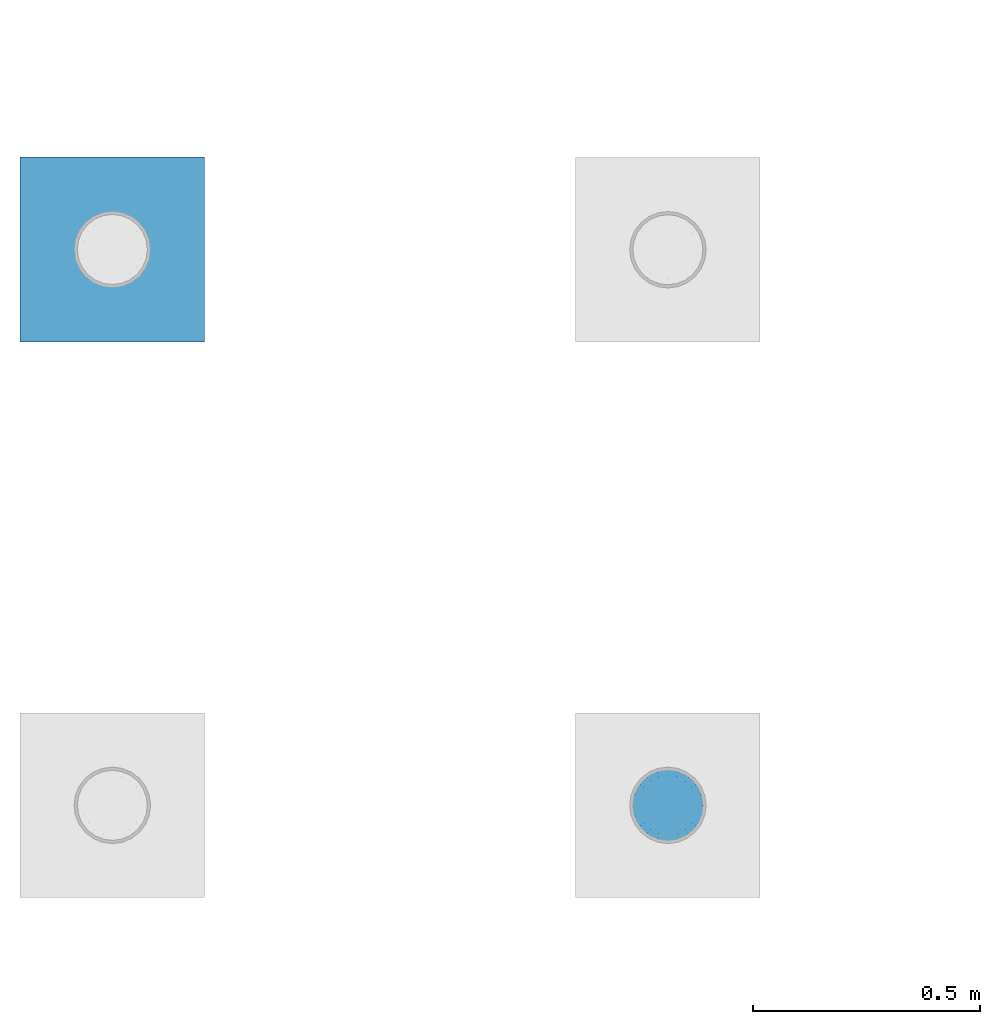
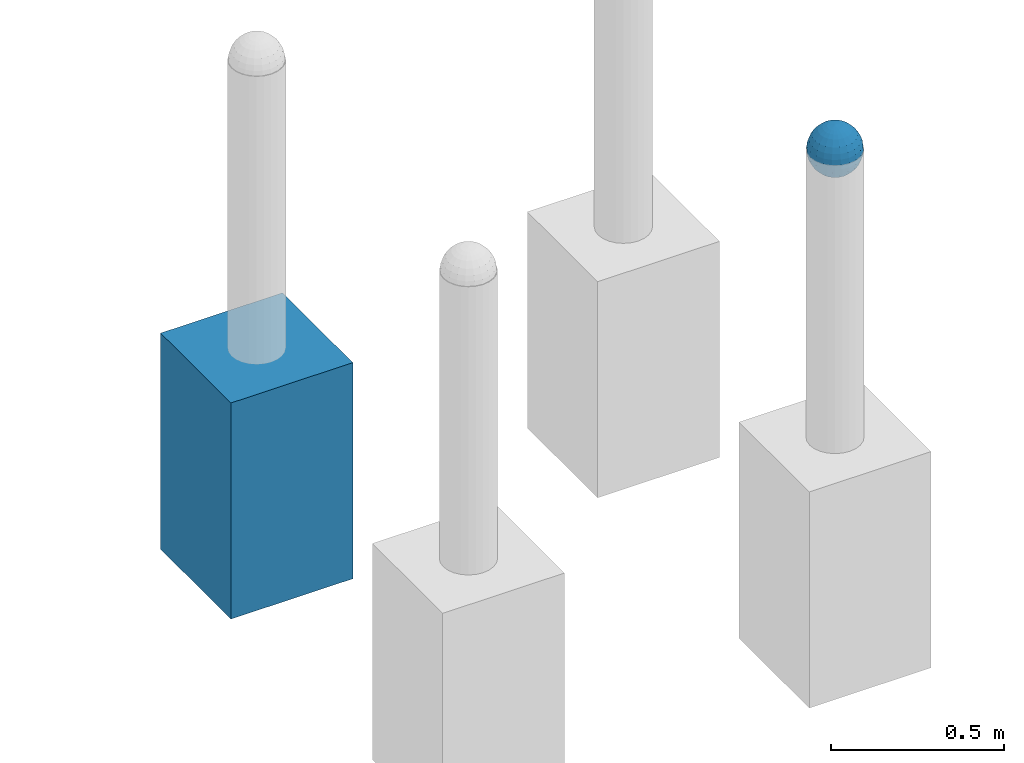
# One storey, part 1433 of 3843: 2 columns, 2 elements without a shape of their own.
"""IFC2X3 building model written with IfcOpenShell, lengths in millimetres."""

from ifc_helpers import new_model, si_unit, frame, origin_with_axes, place, context, subcontext, project, spatial, faceted_brep, material, type_object, element, aggregate, save


model = new_model("IFC2X3")

# Units and contexts
model_context = context("Model", 3, precision=1e-05, world=origin_with_axes())
body_context = subcontext(model_context, "Body", "Model", "MODEL_VIEW")
ifc_project = project(units=[si_unit("LENGTHUNIT", "METRE", prefix="MILLI"), si_unit("AREAUNIT", "SQUARE_METRE"), si_unit("VOLUMEUNIT", "CUBIC_METRE"), si_unit("MASSUNIT", "GRAM", prefix="KILO"), si_unit("TIMEUNIT", "SECOND"), si_unit("PLANEANGLEUNIT", "RADIAN"), si_unit("SOLIDANGLEUNIT", "STERADIAN"), si_unit("THERMODYNAMICTEMPERATUREUNIT", "DEGREE_CELSIUS"), si_unit("LUMINOUSINTENSITYUNIT", "LUMEN")], contexts=[model_context])

# Site, building, storey
site_placement = place(None, origin_with_axes())
site = spatial("IfcSite", under=ifc_project, at=site_placement, CompositionType="ELEMENT")
building_placement = place(site_placement, origin_with_axes())
building = spatial("IfcBuilding", under=site, at=building_placement, Name="Undefined", CompositionType="ELEMENT")
storey_placement = place(building_placement, origin_with_axes())
storey = spatial("IfcBuildingStorey", under=building, at=storey_placement, Name="Undefined", CompositionType="ELEMENT", Elevation=0.0)

# Assembly, column
assembly_1_placement = place(storey_placement, origin_with_axes())
assembly_1 = element("IfcElementAssembly", 1, at=assembly_1_placement, inside=storey, Name="CONC_COL.", AssemblyPlace="NOTDEFINED", PredefinedType="REINFORCEMENT_UNIT")
ifc_material_1 = material(Name="CONCRETE/3000")
column_type_1 = type_object("IfcColumnType", PredefinedType="NOTDEFINED")
column_1_placement = place(assembly_1_placement, frame((-50545.9919130504, 17455.9024050236, 29718.0), z_axis=(-1.0, 0.0, 0.0), x_axis=(0.0, 0.0, 1.0)))
column_1 = element("IfcColumn", 2, at=column_1_placement, type_object=column_type_1, material=ifc_material_1, Name="CONC_COL.", context=body_context, shape_type="Brep", body=[
    faceted_brep([(0.0, 203.199999999997, -203.200000000001), (0.0, 203.199999999997, 203.200000000001), (762.0, 203.199999999997, 203.200000000001), (762.0, 203.199999999997, -203.200000000001), (0.0, -203.199999999997, 203.200000000001), (762.0, -203.199999999997, 203.200000000001), (0.0, -203.199999999997, -203.200000000001), (762.0, -203.199999999997, -203.200000000001)], [[[0, 1, 2, 3]], [[1, 4, 5, 2]], [[4, 6, 7, 5]], [[6, 0, 3, 7]], [[5, 7, 3, 2]], [[6, 4, 1, 0]]]),
])
aggregate(assembly_1, [column_1])

assembly_2_placement = place(storey_placement, origin_with_axes())
assembly_2 = element("IfcElementAssembly", 3, at=assembly_2_placement, inside=storey, Name="CONC. FILL", AssemblyPlace="NOTDEFINED", PredefinedType="REINFORCEMENT_UNIT")
ifc_material_2 = material(Name="CONCRETE/1500")
column_type_2 = type_object("IfcColumnType", PredefinedType="NOTDEFINED")
column_2_placement = place(assembly_2_placement, frame((-49323.3890688121, 16232.6472475529, 31411.8625), z_axis=(-1.0, 0.0, 0.0), x_axis=(0.0, 0.0, 1.0)))
column_2 = element("IfcColumn", 4, at=column_2_placement, type_object=column_type_2, material=ifc_material_2, Name="CONC. FILL", context=body_context, shape_type="Brep", body=[
    faceted_brep([(0.0, 0.0, 2.0), (0.0, -0.619999999995343, 1.89999999999964), (3.36549999999988, -7.1422259999963, 21.9814139999999), (3.36549999999988, 0.0, 23.1139999999996), (0.0, -1.17999999999302, 1.6200000000008), (3.36549999999988, -13.5910319999966, 18.6992260000006), (0.0, -1.61999999999534, 1.18000000000029), (3.36549999999988, -18.699225999997, 13.5910320000003), (0.0, -1.89999999999418, 0.6200000000008), (3.36549999999988, -21.9814139999944, 7.14222599999994), (0.0, -2.0, 0.0), (3.36549999999988, -23.1140000000014, 0.0), (0.0, -1.89999999999418, -0.6200000000008), (3.36549999999988, -21.9814139999944, -7.14222599999994), (0.0, -1.61999999999534, -1.18000000000029), (3.36549999999988, -18.699225999997, -13.5910320000003), (0.0, -1.17999999999302, -1.6200000000008), (3.36549999999988, -13.5910319999966, -18.6992260000006), (0.0, -0.619999999995343, -1.89999999999964), (3.36549999999988, -7.1422259999963, -21.9814139999999), (0.0, 0.0, -2.0), (3.36549999999988, 0.0, -23.1139999999996), (0.0, 0.619999999995343, -1.89999999999964), (3.36549999999988, 7.1422259999963, -21.9814139999999), (0.0, 1.17999999999302, -1.6200000000008), (3.36549999999988, 13.5910319999966, -18.6992260000006), (0.0, 1.61999999999534, -1.18000000000029), (3.36549999999988, 18.699225999997, -13.5910320000003), (0.0, 1.89999999999418, -0.6200000000008), (3.36549999999988, 21.9814139999944, -7.14222599999994), (0.0, 2.0, 0.0), (3.36549999999988, 23.1140000000014, 0.0), (0.0, 1.89999999999418, 0.6200000000008), (3.36549999999988, 21.9814139999944, 7.14222599999994), (0.0, 1.61999999999534, 1.18000000000029), (3.36549999999988, 18.699225999997, 13.5910320000003), (0.0, 1.17999999999302, 1.6200000000008), (3.36549999999988, 13.5910319999966, 18.6992260000006), (0.0, 0.619999999995343, 1.89999999999964), (3.36549999999988, 7.1422259999963, 21.9814139999999), (8.41374999999971, -11.1214661999984, 34.2282018000005), (8.41374999999971, 0.0, 35.9917999999998), (8.41374999999971, -21.1631784000056, 29.1173662000001), (8.41374999999971, -29.1173661999928, 21.1631784000001), (8.41374999999971, -34.2282017999969, 11.1214662000002), (8.41374999999971, -35.9918000000034, 0.0), (8.41374999999971, -34.2282017999969, -11.1214662000002), (8.41374999999971, -29.1173661999928, -21.1631784000001), (8.41374999999971, -21.1631784000056, -29.1173662000001), (8.41374999999971, -11.1214661999984, -34.2282018000005), (8.41374999999971, 0.0, -35.9917999999998), (8.41374999999971, 11.1214661999984, -34.2282018000005), (8.41374999999971, 21.1631784000056, -29.1173662000001), (8.41374999999971, 29.1173661999928, -21.1631784000001), (8.41374999999971, 34.2282017999969, -11.1214662000002), (8.41374999999971, 35.9918000000034, 0.0), (8.41374999999971, 34.2282017999969, 11.1214662000002), (8.41374999999971, 29.1173661999928, 21.1631784000001), (8.41374999999971, 21.1631784000056, 29.1173662000001), (8.41374999999971, 11.1214661999984, 34.2282018000005), (16.8274999999994, -15.3047700000025, 47.1030300000002), (16.8274999999994, 0.0, 49.5300000000007), (16.8274999999994, -29.1236400000053, 40.0697700000001), (16.8274999999994, -40.0697700000019, 29.1236399999998), (16.8274999999994, -47.1030299999984, 15.3047700000006), (16.8274999999994, -49.5299999999988, 0.0), (16.8274999999994, -47.1030299999984, -15.3047700000006), (16.8274999999994, -40.0697700000019, -29.1236399999998), (16.8274999999994, -29.1236400000053, -40.0697700000001), (16.8274999999994, -15.3047700000025, -47.1030300000002), (16.8274999999994, 0.0, -49.5300000000007), (16.8274999999994, 15.3047700000025, -47.1030300000002), (16.8274999999994, 29.1236400000053, -40.0697700000001), (16.8274999999994, 40.0697700000019, -29.1236399999998), (16.8274999999994, 47.1030299999984, -15.3047700000006), (16.8274999999994, 49.5299999999988, 0.0), (16.8274999999994, 47.1030299999984, 15.3047700000006), (16.8274999999994, 40.0697700000019, 29.1236399999998), (16.8274999999994, 29.1236400000053, 40.0697700000001), (16.8274999999994, 15.3047700000025, 47.1030300000002), (33.6549999999988, -20.4063599999936, 62.8040400000009), (33.6549999999988, 0.0, 66.0400000000009), (33.6549999999988, -38.831520000007, 53.4263599999995), (33.6549999999988, -53.4263599999977, 38.8315199999997), (33.6549999999988, -62.8040400000027, 20.4063600000009), (33.6549999999988, -66.0399999999936, 0.0), (33.6549999999988, -62.8040400000027, -20.4063600000009), (33.6549999999988, -53.4263599999977, -38.8315199999997), (33.6549999999988, -38.831520000007, -53.4263599999995), (33.6549999999988, -20.4063599999936, -62.8040400000009), (33.6549999999988, 0.0, -66.0400000000009), (33.6549999999988, 20.4063599999936, -62.8040400000009), (33.6549999999988, 38.831520000007, -53.4263599999995), (33.6549999999988, 53.4263599999977, -38.8315199999997), (33.6549999999988, 62.8040400000027, -20.4063600000009), (33.6549999999988, 66.0399999999936, 0.0), (33.6549999999988, 62.8040400000027, 20.4063600000009), (33.6549999999988, 53.4263599999977, 38.8315199999997), (33.6549999999988, 38.831520000007, 53.4263599999995), (33.6549999999988, 20.4063599999936, 62.8040400000009), (50.4824999999983, -23.3907901500061, 71.9891308499991), (50.4824999999983, 0.0, 75.6983500000006), (50.4824999999983, -44.5106298000028, 61.23996515), (50.4824999999983, -61.2399651500018, 44.5106297999992), (50.4824999999983, -71.9891308499937, 23.3907901500006), (50.4824999999983, -75.698350000006, 0.0), (50.4824999999983, -71.9891308499937, -23.3907901500006), (50.4824999999983, -61.2399651500018, -44.5106297999992), (50.4824999999983, -44.5106298000028, -61.23996515), (50.4824999999983, -23.3907901500061, -71.9891308499991), (50.4824999999983, 0.0, -75.6983500000006), (50.4824999999983, 23.3907901500061, -71.9891308499991), (50.4824999999983, 44.5106298000028, -61.23996515), (50.4824999999983, 61.2399651500018, -44.5106297999992), (50.4824999999983, 71.9891308499937, -23.3907901500006), (50.4824999999983, 75.698350000006, 0.0), (50.4824999999983, 71.9891308499937, 23.3907901500006), (50.4824999999983, 61.2399651500018, 44.5106297999992), (50.4824999999983, 44.5106298000028, 61.23996515), (50.4824999999983, 23.3907901500061, 71.9891308499991), (67.3099999999977, -24.9977910000016, 76.9349490000004), (67.3099999999977, 0.0, 80.8989999999994), (67.3099999999977, -47.5686120000028, 65.4472910000004), (67.3099999999977, -65.447291000004, 47.5686119999991), (67.3099999999977, -76.9349490000022, 24.9977909999998), (67.3099999999977, -80.8990000000049, 0.0), (67.3099999999977, -76.9349490000022, -24.9977909999998), (67.3099999999977, -65.447291000004, -47.5686119999991), (67.3099999999977, -47.5686120000028, -65.4472910000004), (67.3099999999977, -24.9977910000016, -76.9349490000004), (67.3099999999977, 0.0, -80.8989999999994), (67.3099999999977, 24.9977910000016, -76.9349490000004), (67.3099999999977, 47.5686120000028, -65.4472910000004), (67.3099999999977, 65.447291000004, -47.5686119999991), (67.3099999999977, 76.9349490000022, -24.9977909999998), (67.3099999999977, 80.8990000000049, 0.0), (67.3099999999977, 76.9349490000022, 24.9977909999998), (67.3099999999977, 65.447291000004, 47.5686119999991), (67.3099999999977, 47.5686120000028, 65.4472910000004), (67.3099999999977, 24.9977910000016, 76.9349490000004), (84.1374999999935, -25.5079499999993, 78.5050499999998), (84.1374999999935, 0.0, 82.5499999999993), (84.1374999999935, -48.5393999999942, 66.7829500000007), (84.1374999999935, -66.7829499999934, 48.5393999999997), (84.1374999999935, -78.505050000007, 25.5079499999993), (84.1374999999935, -82.5500000000029, 0.0), (84.1374999999935, -78.505050000007, -25.5079499999993), (84.1374999999935, -66.7829499999934, -48.5393999999997), (84.1374999999935, -48.5393999999942, -66.7829500000007), (84.1374999999935, -25.5079499999993, -78.5050499999998), (84.1374999999935, 0.0, -82.5499999999993), (84.1374999999935, 25.5079499999993, -78.5050499999998), (84.1374999999935, 48.5393999999942, -66.7829500000007), (84.1374999999935, 66.7829499999934, -48.5393999999997), (84.1374999999935, 78.505050000007, -25.5079499999993), (84.1374999999935, 82.5500000000029, 0.0), (84.1374999999935, 78.505050000007, 25.5079499999993), (84.1374999999935, 66.7829499999934, 48.5393999999997), (84.1374999999935, 48.5393999999942, 66.7829500000007), (84.1374999999935, 25.5079499999993, 78.5050499999998), (100.964999999993, -24.9977910000016, 76.9349490000004), (100.964999999993, 0.0, 80.8989999999994), (100.964999999993, -47.5686120000028, 65.4472910000004), (100.964999999993, -65.447291000004, 47.5686119999991), (100.964999999993, -76.9349490000022, 24.9977909999998), (100.964999999993, -80.8990000000049, 0.0), (100.964999999993, -76.9349490000022, -24.9977909999998), (100.964999999993, -65.447291000004, -47.5686119999991), (100.964999999993, -47.5686120000028, -65.4472910000004), (100.964999999993, -24.9977910000016, -76.9349490000004), (100.964999999993, 0.0, -80.8989999999994), (100.964999999993, 24.9977910000016, -76.9349490000004), (100.964999999993, 47.5686120000028, -65.4472910000004), (100.964999999993, 65.447291000004, -47.5686119999991), (100.964999999993, 76.9349490000022, -24.9977909999998), (100.964999999993, 80.8990000000049, 0.0), (100.964999999993, 76.9349490000022, 24.9977909999998), (100.964999999993, 65.447291000004, 47.5686119999991), (100.964999999993, 47.5686120000028, 65.4472910000004), (100.964999999993, 24.9977910000016, 76.9349490000004), (117.792499999992, -23.3907901500061, 71.9891308499991), (117.792499999992, 0.0, 75.6983500000006), (117.792499999992, -44.5106298000028, 61.23996515), (117.792499999992, -61.2399651500018, 44.5106297999992), (117.792499999992, -71.9891308499937, 23.3907901500006), (117.792499999992, -75.698350000006, 0.0), (117.792499999992, -71.9891308499937, -23.3907901500006), (117.792499999992, -61.2399651500018, -44.5106297999992), (117.792499999992, -44.5106298000028, -61.23996515), (117.792499999992, -23.3907901500061, -71.9891308499991), (117.792499999992, 0.0, -75.6983500000006), (117.792499999992, 23.3907901500061, -71.9891308499991), (117.792499999992, 44.5106298000028, -61.23996515), (117.792499999992, 61.2399651500018, -44.5106297999992), (117.792499999992, 71.9891308499937, -23.3907901500006), (117.792499999992, 75.698350000006, 0.0), (117.792499999992, 71.9891308499937, 23.3907901500006), (117.792499999992, 61.2399651500018, 44.5106297999992), (117.792499999992, 44.5106298000028, 61.23996515), (117.792499999992, 23.3907901500061, 71.9891308499991), (134.619999999992, -20.4063599999936, 62.8040400000009), (134.619999999992, 0.0, 66.0400000000009), (134.619999999992, -38.831520000007, 53.4263599999995), (134.619999999992, -53.4263599999977, 38.8315199999997), (134.619999999992, -62.8040400000027, 20.4063600000009), (134.619999999992, -66.0399999999936, 0.0), (134.619999999992, -62.8040400000027, -20.4063600000009), (134.619999999992, -53.4263599999977, -38.8315199999997), (134.619999999992, -38.831520000007, -53.4263599999995), (134.619999999992, -20.4063599999936, -62.8040400000009), (134.619999999992, 0.0, -66.0400000000009), (134.619999999992, 20.4063599999936, -62.8040400000009), (134.619999999992, 38.831520000007, -53.4263599999995), (134.619999999992, 53.4263599999977, -38.8315199999997), (134.619999999992, 62.8040400000027, -20.4063600000009), (134.619999999992, 66.0399999999936, 0.0), (134.619999999992, 62.8040400000027, 20.4063600000009), (134.619999999992, 53.4263599999977, 38.8315199999997), (134.619999999992, 38.831520000007, 53.4263599999995), (134.619999999992, 20.4063599999936, 62.8040400000009), (151.447499999991, -15.3047700000025, 47.1030300000002), (151.447499999991, 0.0, 49.5300000000007), (151.447499999991, -29.1236400000053, 40.0697700000001), (151.447499999991, -40.0697700000019, 29.1236399999998), (151.447499999991, -47.1030299999984, 15.3047700000006), (151.447499999991, -49.5299999999988, 0.0), (151.447499999991, -47.1030299999984, -15.3047700000006), (151.447499999991, -40.0697700000019, -29.1236399999998), (151.447499999991, -29.1236400000053, -40.0697700000001), (151.447499999991, -15.3047700000025, -47.1030300000002), (151.447499999991, 0.0, -49.5300000000007), (151.447499999991, 15.3047700000025, -47.1030300000002), (151.447499999991, 29.1236400000053, -40.0697700000001), (151.447499999991, 40.0697700000019, -29.1236399999998), (151.447499999991, 47.1030299999984, -15.3047700000006), (151.447499999991, 49.5299999999988, 0.0), (151.447499999991, 47.1030299999984, 15.3047700000006), (151.447499999991, 40.0697700000019, 29.1236399999998), (151.447499999991, 29.1236400000053, 40.0697700000001), (151.447499999991, 15.3047700000025, 47.1030300000002), (159.861249999991, -11.1214661999984, 34.2282018000005), (159.861249999991, 0.0, 35.9917999999998), (159.861249999991, -21.1631784000056, 29.1173662000001), (159.861249999991, -29.1173661999928, 21.1631784000001), (159.861249999991, -34.2282017999969, 11.1214662000002), (159.861249999991, -35.9918000000034, 0.0), (159.861249999991, -34.2282017999969, -11.1214662000002), (159.861249999991, -29.1173661999928, -21.1631784000001), (159.861249999991, -21.1631784000056, -29.1173662000001), (159.861249999991, -11.1214661999984, -34.2282018000005), (159.861249999991, 0.0, -35.9917999999998), (159.861249999991, 11.1214661999984, -34.2282018000005), (159.861249999991, 21.1631784000056, -29.1173662000001), (159.861249999991, 29.1173661999928, -21.1631784000001), (159.861249999991, 34.2282017999969, -11.1214662000002), (159.861249999991, 35.9918000000034, 0.0), (159.861249999991, 34.2282017999969, 11.1214662000002), (159.861249999991, 29.1173661999928, 21.1631784000001), (159.861249999991, 21.1631784000056, 29.1173662000001), (159.861249999991, 11.1214661999984, 34.2282018000005), (164.909499999991, -7.1422259999963, 21.9814139999999), (164.909499999991, 0.0, 23.1139999999996), (164.909499999991, -13.5910319999966, 18.6992260000006), (164.909499999991, -18.699225999997, 13.5910320000003), (164.909499999991, -21.9814139999944, 7.14222599999994), (164.909499999991, -23.1140000000014, 0.0), (164.909499999991, -21.9814139999944, -7.14222599999994), (164.909499999991, -18.699225999997, -13.5910320000003), (164.909499999991, -13.5910319999966, -18.6992260000006), (164.909499999991, -7.1422259999963, -21.9814139999999), (164.909499999991, 0.0, -23.1139999999996), (164.909499999991, 7.1422259999963, -21.9814139999999), (164.909499999991, 13.5910319999966, -18.6992260000006), (164.909499999991, 18.699225999997, -13.5910320000003), (164.909499999991, 21.9814139999944, -7.14222599999994), (164.909499999991, 23.1140000000014, 0.0), (164.909499999991, 21.9814139999944, 7.14222599999994), (164.909499999991, 18.699225999997, 13.5910320000003), (164.909499999991, 13.5910319999966, 18.6992260000006), (164.909499999991, 7.1422259999963, 21.9814139999999), (168.274999999991, -0.619999999995343, 1.89999999999964), (168.274999999991, 0.0, 2.0), (168.274999999991, -1.17999999999302, 1.6200000000008), (168.274999999991, -1.61999999999534, 1.18000000000029), (168.274999999991, -1.89999999999418, 0.6200000000008), (168.274999999991, -2.0, 0.0), (168.274999999991, -1.89999999999418, -0.6200000000008), (168.274999999991, -1.61999999999534, -1.18000000000029), (168.274999999991, -1.17999999999302, -1.6200000000008), (168.274999999991, -0.619999999995343, -1.89999999999964), (168.274999999991, 0.0, -2.0), (168.274999999991, 0.619999999995343, -1.89999999999964), (168.274999999991, 1.17999999999302, -1.6200000000008), (168.274999999991, 1.61999999999534, -1.18000000000029), (168.274999999991, 1.89999999999418, -0.6200000000008), (168.274999999991, 2.0, 0.0), (168.274999999991, 1.89999999999418, 0.6200000000008), (168.274999999991, 1.61999999999534, 1.18000000000029), (168.274999999991, 1.17999999999302, 1.6200000000008), (168.274999999991, 0.619999999995343, 1.89999999999964)], [[[0, 1, 2, 3]], [[1, 4, 5, 2]], [[4, 6, 7, 5]], [[6, 8, 9, 7]], [[8, 10, 11, 9]], [[10, 12, 13, 11]], [[12, 14, 15, 13]], [[14, 16, 17, 15]], [[16, 18, 19, 17]], [[18, 20, 21, 19]], [[20, 22, 23, 21]], [[22, 24, 25, 23]], [[24, 26, 27, 25]], [[26, 28, 29, 27]], [[28, 30, 31, 29]], [[30, 32, 33, 31]], [[32, 34, 35, 33]], [[34, 36, 37, 35]], [[36, 38, 39, 37]], [[38, 0, 3, 39]], [[38, 36, 34, 32, 30, 28, 26, 24, 22, 20, 18, 16, 14, 12, 10, 8, 6, 4, 1, 0]], [[3, 2, 40, 41]], [[2, 5, 42, 40]], [[5, 7, 43, 42]], [[7, 9, 44, 43]], [[9, 11, 45, 44]], [[11, 13, 46, 45]], [[13, 15, 47, 46]], [[15, 17, 48, 47]], [[17, 19, 49, 48]], [[19, 21, 50, 49]], [[21, 23, 51, 50]], [[23, 25, 52, 51]], [[25, 27, 53, 52]], [[27, 29, 54, 53]], [[29, 31, 55, 54]], [[31, 33, 56, 55]], [[33, 35, 57, 56]], [[35, 37, 58, 57]], [[37, 39, 59, 58]], [[39, 3, 41, 59]], [[41, 40, 60, 61]], [[40, 42, 62, 60]], [[42, 43, 63, 62]], [[43, 44, 64, 63]], [[44, 45, 65, 64]], [[45, 46, 66, 65]], [[46, 47, 67, 66]], [[47, 48, 68, 67]], [[48, 49, 69, 68]], [[49, 50, 70, 69]], [[50, 51, 71, 70]], [[51, 52, 72, 71]], [[52, 53, 73, 72]], [[53, 54, 74, 73]], [[54, 55, 75, 74]], [[55, 56, 76, 75]], [[56, 57, 77, 76]], [[57, 58, 78, 77]], [[58, 59, 79, 78]], [[59, 41, 61, 79]], [[61, 60, 80, 81]], [[60, 62, 82, 80]], [[62, 63, 83, 82]], [[63, 64, 84, 83]], [[64, 65, 85, 84]], [[65, 66, 86, 85]], [[66, 67, 87, 86]], [[67, 68, 88, 87]], [[68, 69, 89, 88]], [[69, 70, 90, 89]], [[70, 71, 91, 90]], [[71, 72, 92, 91]], [[72, 73, 93, 92]], [[73, 74, 94, 93]], [[74, 75, 95, 94]], [[75, 76, 96, 95]], [[76, 77, 97, 96]], [[77, 78, 98, 97]], [[78, 79, 99, 98]], [[79, 61, 81, 99]], [[81, 80, 100, 101]], [[80, 82, 102, 100]], [[82, 83, 103, 102]], [[83, 84, 104, 103]], [[84, 85, 105, 104]], [[85, 86, 106, 105]], [[86, 87, 107, 106]], [[87, 88, 108, 107]], [[88, 89, 109, 108]], [[89, 90, 110, 109]], [[90, 91, 111, 110]], [[91, 92, 112, 111]], [[92, 93, 113, 112]], [[93, 94, 114, 113]], [[94, 95, 115, 114]], [[95, 96, 116, 115]], [[96, 97, 117, 116]], [[97, 98, 118, 117]], [[98, 99, 119, 118]], [[99, 81, 101, 119]], [[101, 100, 120, 121]], [[100, 102, 122, 120]], [[102, 103, 123, 122]], [[103, 104, 124, 123]], [[104, 105, 125, 124]], [[105, 106, 126, 125]], [[106, 107, 127, 126]], [[107, 108, 128, 127]], [[108, 109, 129, 128]], [[109, 110, 130, 129]], [[110, 111, 131, 130]], [[111, 112, 132, 131]], [[112, 113, 133, 132]], [[113, 114, 134, 133]], [[114, 115, 135, 134]], [[115, 116, 136, 135]], [[116, 117, 137, 136]], [[117, 118, 138, 137]], [[118, 119, 139, 138]], [[119, 101, 121, 139]], [[121, 120, 140, 141]], [[120, 122, 142, 140]], [[122, 123, 143, 142]], [[123, 124, 144, 143]], [[124, 125, 145, 144]], [[125, 126, 146, 145]], [[126, 127, 147, 146]], [[127, 128, 148, 147]], [[128, 129, 149, 148]], [[129, 130, 150, 149]], [[130, 131, 151, 150]], [[131, 132, 152, 151]], [[132, 133, 153, 152]], [[133, 134, 154, 153]], [[134, 135, 155, 154]], [[135, 136, 156, 155]], [[136, 137, 157, 156]], [[137, 138, 158, 157]], [[138, 139, 159, 158]], [[139, 121, 141, 159]], [[141, 140, 160, 161]], [[140, 142, 162, 160]], [[142, 143, 163, 162]], [[143, 144, 164, 163]], [[144, 145, 165, 164]], [[145, 146, 166, 165]], [[146, 147, 167, 166]], [[147, 148, 168, 167]], [[148, 149, 169, 168]], [[149, 150, 170, 169]], [[150, 151, 171, 170]], [[151, 152, 172, 171]], [[152, 153, 173, 172]], [[153, 154, 174, 173]], [[154, 155, 175, 174]], [[155, 156, 176, 175]], [[156, 157, 177, 176]], [[157, 158, 178, 177]], [[158, 159, 179, 178]], [[159, 141, 161, 179]], [[161, 160, 180, 181]], [[160, 162, 182, 180]], [[162, 163, 183, 182]], [[163, 164, 184, 183]], [[164, 165, 185, 184]], [[165, 166, 186, 185]], [[166, 167, 187, 186]], [[167, 168, 188, 187]], [[168, 169, 189, 188]], [[169, 170, 190, 189]], [[170, 171, 191, 190]], [[171, 172, 192, 191]], [[172, 173, 193, 192]], [[173, 174, 194, 193]], [[174, 175, 195, 194]], [[175, 176, 196, 195]], [[176, 177, 197, 196]], [[177, 178, 198, 197]], [[178, 179, 199, 198]], [[179, 161, 181, 199]], [[181, 180, 200, 201]], [[180, 182, 202, 200]], [[182, 183, 203, 202]], [[183, 184, 204, 203]], [[184, 185, 205, 204]], [[185, 186, 206, 205]], [[186, 187, 207, 206]], [[187, 188, 208, 207]], [[188, 189, 209, 208]], [[189, 190, 210, 209]], [[190, 191, 211, 210]], [[191, 192, 212, 211]], [[192, 193, 213, 212]], [[193, 194, 214, 213]], [[194, 195, 215, 214]], [[195, 196, 216, 215]], [[196, 197, 217, 216]], [[197, 198, 218, 217]], [[198, 199, 219, 218]], [[199, 181, 201, 219]], [[201, 200, 220, 221]], [[200, 202, 222, 220]], [[202, 203, 223, 222]], [[203, 204, 224, 223]], [[204, 205, 225, 224]], [[205, 206, 226, 225]], [[206, 207, 227, 226]], [[207, 208, 228, 227]], [[208, 209, 229, 228]], [[209, 210, 230, 229]], [[210, 211, 231, 230]], [[211, 212, 232, 231]], [[212, 213, 233, 232]], [[213, 214, 234, 233]], [[214, 215, 235, 234]], [[215, 216, 236, 235]], [[216, 217, 237, 236]], [[217, 218, 238, 237]], [[218, 219, 239, 238]], [[219, 201, 221, 239]], [[221, 220, 240, 241]], [[220, 222, 242, 240]], [[222, 223, 243, 242]], [[223, 224, 244, 243]], [[224, 225, 245, 244]], [[225, 226, 246, 245]], [[226, 227, 247, 246]], [[227, 228, 248, 247]], [[228, 229, 249, 248]], [[229, 230, 250, 249]], [[230, 231, 251, 250]], [[231, 232, 252, 251]], [[232, 233, 253, 252]], [[233, 234, 254, 253]], [[234, 235, 255, 254]], [[235, 236, 256, 255]], [[236, 237, 257, 256]], [[237, 238, 258, 257]], [[238, 239, 259, 258]], [[239, 221, 241, 259]], [[241, 240, 260, 261]], [[240, 242, 262, 260]], [[242, 243, 263, 262]], [[243, 244, 264, 263]], [[244, 245, 265, 264]], [[245, 246, 266, 265]], [[246, 247, 267, 266]], [[247, 248, 268, 267]], [[248, 249, 269, 268]], [[249, 250, 270, 269]], [[250, 251, 271, 270]], [[251, 252, 272, 271]], [[252, 253, 273, 272]], [[253, 254, 274, 273]], [[254, 255, 275, 274]], [[255, 256, 276, 275]], [[256, 257, 277, 276]], [[257, 258, 278, 277]], [[258, 259, 279, 278]], [[259, 241, 261, 279]], [[261, 260, 280, 281]], [[260, 262, 282, 280]], [[262, 263, 283, 282]], [[263, 264, 284, 283]], [[264, 265, 285, 284]], [[265, 266, 286, 285]], [[266, 267, 287, 286]], [[267, 268, 288, 287]], [[268, 269, 289, 288]], [[269, 270, 290, 289]], [[270, 271, 291, 290]], [[271, 272, 292, 291]], [[272, 273, 293, 292]], [[273, 274, 294, 293]], [[274, 275, 295, 294]], [[275, 276, 296, 295]], [[276, 277, 297, 296]], [[277, 278, 298, 297]], [[278, 279, 299, 298]], [[279, 261, 281, 299]], [[282, 283, 284, 285, 286, 287, 288, 289, 290, 291, 292, 293, 294, 295, 296, 297, 298, 299, 281, 280]]]),
])
aggregate(assembly_2, [column_2])

save(model, "model.ifc")
